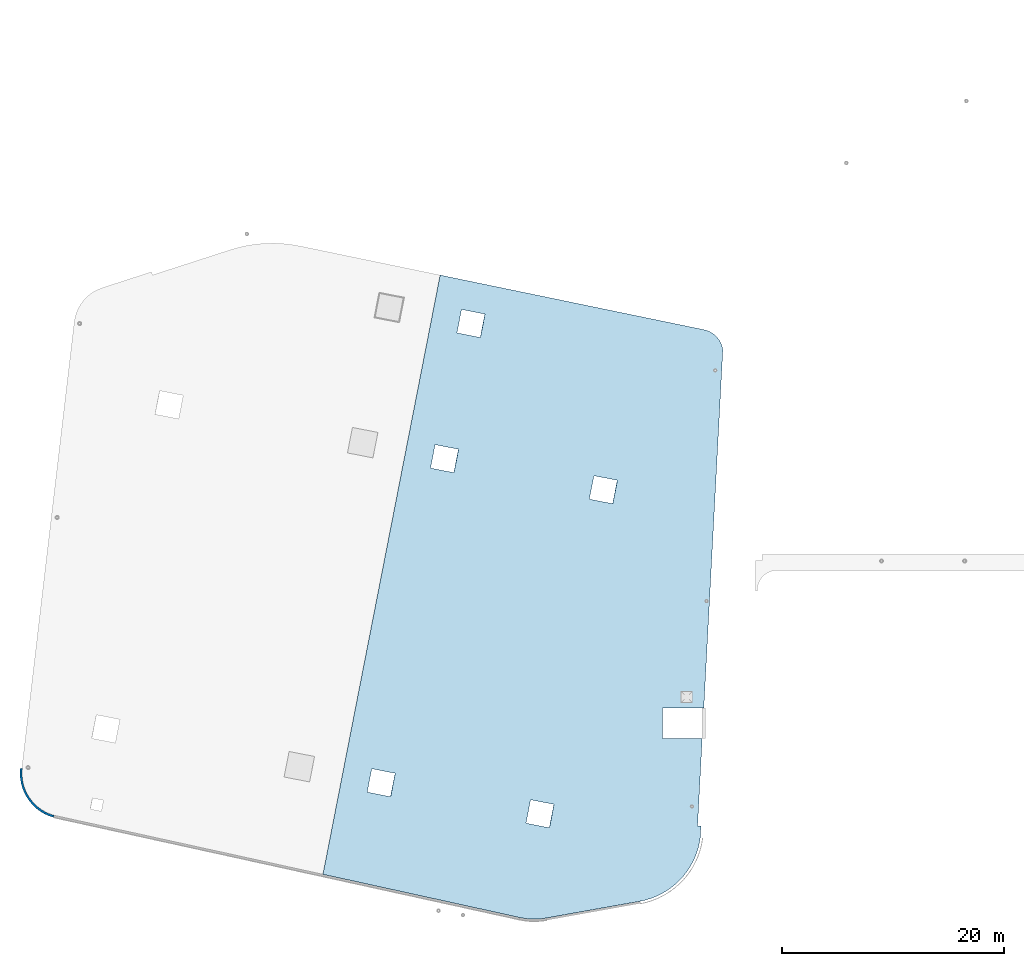
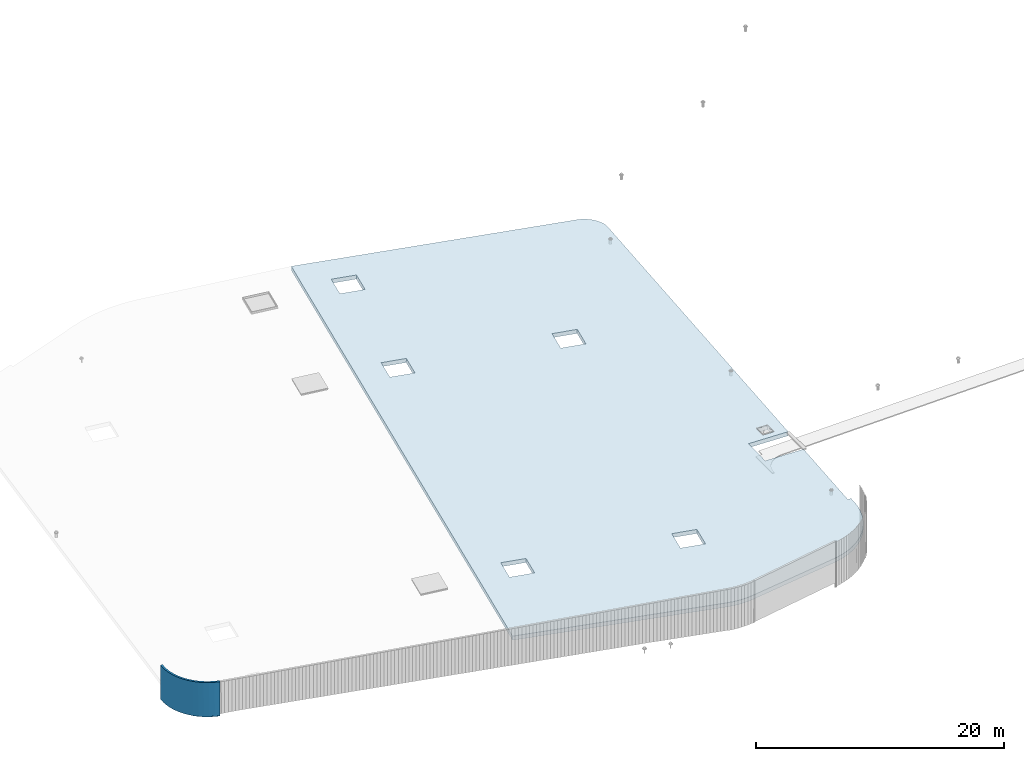
# One storey, part 9 of 18: 1 roof, 1 wall.
"""IFC2X3 building model written with IfcOpenShell, lengths in centimetres."""

from ifc_helpers import new_model, entity, si_unit, converted_unit, derived_unit, direction, frame, origin, place, context, subcontext, project, spatial, faceted_brep, material, layer, layer_set, type_object, element, save


model = new_model("IFC2X3")

# Units and contexts
model_context = context("Model", 3, precision=0.001, world=origin(), true_north=direction((6.12303176911189e-17, 1.0)))
body_context = subcontext(model_context, "Body", "Model", "MODEL_VIEW")
ifc_project = project(units=[si_unit("LENGTHUNIT", "METRE", prefix="CENTI"), si_unit("AREAUNIT", "SQUARE_METRE"), si_unit("VOLUMEUNIT", "CUBIC_METRE"), converted_unit("PLANEANGLEUNIT", "DEGREE", entity("IfcRatioMeasure", 0.0174532925199433), si_unit("PLANEANGLEUNIT", "RADIAN"), dimensions=[0, 0, 0, 0, 0, 0, 0]), si_unit("MASSUNIT", "GRAM", prefix="KILO"), derived_unit("MASSDENSITYUNIT", [(si_unit("MASSUNIT", "GRAM", prefix="KILO"), 1), (si_unit("LENGTHUNIT", "METRE"), -3)]), si_unit("TIMEUNIT", "SECOND"), si_unit("FREQUENCYUNIT", "HERTZ"), si_unit("THERMODYNAMICTEMPERATUREUNIT", "DEGREE_CELSIUS"), derived_unit("THERMALTRANSMITTANCEUNIT", [(si_unit("MASSUNIT", "GRAM", prefix="KILO"), 1), (si_unit("THERMODYNAMICTEMPERATUREUNIT", "KELVIN"), -1), (si_unit("TIMEUNIT", "SECOND"), -3)]), derived_unit("VOLUMETRICFLOWRATEUNIT", [(si_unit("LENGTHUNIT", "METRE"), 3), (si_unit("TIMEUNIT", "SECOND"), -1)]), si_unit("ELECTRICCURRENTUNIT", "AMPERE"), si_unit("ELECTRICVOLTAGEUNIT", "VOLT"), si_unit("POWERUNIT", "WATT"), si_unit("FORCEUNIT", "NEWTON", prefix="KILO"), si_unit("ILLUMINANCEUNIT", "LUX"), si_unit("LUMINOUSFLUXUNIT", "LUMEN"), si_unit("LUMINOUSINTENSITYUNIT", "CANDELA"), derived_unit("USERDEFINED", [(si_unit("MASSUNIT", "GRAM", prefix="KILO"), -1), (si_unit("LENGTHUNIT", "METRE"), -2), (si_unit("TIMEUNIT", "SECOND"), 3), (si_unit("LUMINOUSFLUXUNIT", "LUMEN"), 1)]), derived_unit("LINEARVELOCITYUNIT", [(si_unit("LENGTHUNIT", "METRE"), 1), (si_unit("TIMEUNIT", "SECOND"), -1)]), si_unit("PRESSUREUNIT", "PASCAL"), derived_unit("USERDEFINED", [(si_unit("LENGTHUNIT", "METRE"), -2), (si_unit("MASSUNIT", "GRAM", prefix="KILO"), 1), (si_unit("TIMEUNIT", "SECOND"), -2)])], contexts=[model_context])

# Site, building, storey
site_placement = place(None, origin())
site = spatial("IfcSite", under=ifc_project, at=site_placement, CompositionType="ELEMENT")
building_placement = place(site_placement, origin())
building = spatial("IfcBuilding", under=site, at=building_placement, CompositionType="ELEMENT")
storey_placement = place(building_placement, frame((0.0, 0.0, 1422.0)))
storey = spatial("IfcBuildingStorey", under=building, at=storey_placement, CompositionType="ELEMENT", Elevation=1422.0)

# Wall
ifc_material_1 = material(Name="Isolation")
ifc_layer_1 = layer(ifc_material_1, 10.0)
ifc_layer_2 = layer(ifc_material_1, 9.0)
ifc_material_2 = material(Name="Acier")
ifc_layer_3 = layer(ifc_material_2, 1.0)
ifc_layer_set = layer_set([ifc_layer_1, ifc_layer_2, ifc_layer_3])
wall_type = type_object("IfcWallType", PredefinedType="NOTDEFINED", material=ifc_layer_set)
wall_placement = place(storey_placement, frame((4062.69917392711, 1090.74013214278, -337.171375491842)))
element("IfcWall", 1, at=wall_placement, inside=storey, type_object=wall_type, context=body_context, shape_type="Brep", body=[
    faceted_brep([(-2.33072035438746, -8.43387471033597, 337.171375491841), (2.66368040501164, 9.63871395467039, 337.171375491841), (-18.5968051409579, 16.1678271243607, 337.171375491841), (-39.4533452253409, 23.8906698743825, 337.171375491841), (-59.8389745144359, 32.7824460141989, 337.171375491841), (-79.6882396558412, 42.8146061893157, 337.171375491841), (-98.9374094334242, 53.9549395463922, 337.171375491841), (-117.524679392928, 66.1676771545426, 337.171375491841), (-135.390370281209, 79.4136068507712, 337.171375491841), (-152.477119661962, 93.6501991407951, 337.171375491841), (-168.730066092708, 108.831743751021, 337.171375491841), (-184.097025271693, 124.909496393242, 337.171375491841), (-198.528657589123, 141.831835270817, 337.171375491841), (-211.978626544792, 159.54442682385, 337.171375491841), (-224.403747523429, 177.990400181178, 337.171375491841), (-235.76412645012, 197.11052975906, 337.171375491841), (-246.023287880582, 216.843425420284, 337.171375491841), (-255.148292115042, 237.125729583127, 337.171375491841), (-263.109840959691, 257.892320647317, 337.171375491841), (-269.882371796138, 279.076522083821, 337.171375491841), (-275.444139656826, 300.610316517149, 337.171375491841), (-279.777287042898, 322.424564112783, 337.171375491841), (-282.867901260324, 344.449224568555, 337.171375491841), (-284.706059090221, 366.613581997215, 337.171375491841), (-285.285858649921, 388.846471978133, 337.171375491841), (-284.605438342493, 411.076510049136, 337.171375491841), (-282.666982833885, 433.23232090485, 337.171375491841), (-301.291829289407, 435.395095629182, 337.171375491841), (-304.027845965021, 390.681654434054, 337.171375491841), (-301.884267243905, 345.93589842272, 337.171375491841), (-294.886527840281, 301.688760051991, 337.171375491841), (-283.117659695162, 258.465255412243, 337.171375491841), (-266.717306757722, 216.778254629184, 337.171375491841), (-245.880068034744, 177.122396384013, 337.171375491841), (-220.853188568764, 139.968218759488, 337.171375491841), (-191.933625742688, 105.756576052537, 337.171375491841), (-159.464525720749, 74.893407800965, 337.171375491841), (-123.831151834755, 47.7449220925424, 337.171375491841), (-85.4563132274757, 24.6332503091194, 337.171375491841), (-44.7953479948021, 5.83262486455579, 337.171375491841), (-282.482883397519, 256.567313356663, 0.15952722359159), (-294.568987883701, 300.221772277532, 0.15952722359159), (-301.780808834091, 344.94062002548, 0.15952722359159), (-304.030854899511, 390.181342809585, 0.15952722359159), (-301.291829289407, 435.395095629185, 0.15952722359159), (-282.666982833885, 433.23232090485, 0.15952722359159), (-284.605438342493, 411.076510049136, 0.15952722359159), (-285.285858649921, 388.846471978133, 0.15952722359159), (-284.706059090221, 366.613581997215, 0.15952722359159), (-282.867901260324, 344.449224568555, 0.15952722359159), (-279.777287042898, 322.424564112783, 0.15952722359159), (-275.444139656826, 300.610316517149, 0.15952722359159), (-269.882371796138, 279.076522083821, 0.15952722359159), (-263.109840959691, 257.892320647317, 0.15952722359159), (-255.148292115042, 237.125729583127, 0.15952722359159), (-246.023287880582, 216.843425420284, 0.15952722359159), (-235.76412645012, 197.11052975906, 0.15952722359159), (-224.403747523429, 177.990400181178, 0.15952722359159), (-211.978626544792, 159.54442682385, 0.15952722359159), (-198.528657589123, 141.831835270817, 0.15952722359159), (-184.097025271693, 124.909496393242, 0.15952722359159), (-168.730066092708, 108.831743751021, 0.15952722359159), (-152.477119661962, 93.6501991407951, 0.15952722359159), (-135.390370281209, 79.4136068507712, 0.15952722359159), (-117.524679392928, 66.1676771545426, 0.15952722359159), (-98.9374094334242, 53.9549395463922, 0.15952722359159), (-79.6882396558412, 42.8146061893157, 0.15952722359159), (-59.8389745144359, 32.7824460141989, 0.15952722359159), (-39.4533452253409, 23.8906698743825, 0.15952722359159), (-18.5968051409579, 16.1678271243607, 0.15952722359159), (2.66368040501164, 9.63871395467039, 0.15952722359159), (-2.66368040501424, -9.63871395466974, 0.15952722359159), (-23.7103234825644, -2.58312497189322, 0.15952722359159), (-44.7569665601129, 4.47246401088265, 0.15952722359159), (-64.9234442894792, 13.7490632100807, 0.15952722359159), (-85.0899220188463, 23.025662409279, 0.15952722359159), (-104.142641930281, 34.4158159181314, 0.15952722359159), (-123.195361841715, 45.8059694269839, 0.15952722359159), (-140.91363278646, 59.1777398507389, 0.15952722359159), (-158.631903731205, 72.549510274494, 0.15952722359159), (-170.567897284334, 83.7624266847847, 0.15952722359159), (-190.989080500356, 102.946503769046, 0.15952722359159), (-189.172921733311, 102.858487285105, 0.15952722359159), (-218.72941077487, 137.183400407514, 0.15952722359159), (-244.331676133505, 174.550628212513, 0.15952722359159), (-265.669119868183, 214.506844252001, 0.15952722359159), (-140.913599446718, 59.1777152729271, 2.22420308156823), (-123.195320261424, 45.8059414264352, 2.84912430087587), (-2.66368040502203, -9.63871395466757, 5.32638347245524), (-29.1064307092239, -0.774157690488049, 4.94767486458409), (-158.631878632013, 72.549489119419, 1.59928186226037), (-171.090299567969, 84.2531835625409, 1.04493635964215), (-149.772739039365, 65.863602196173, 1.91174247191419), (-104.142598564454, 34.41579002149, 3.37185078444104), (-64.9234056158152, 13.7490449343065, 4.30905413006593), (-44.7569343641454, 4.47245125206806, 4.72353099212565), (-85.0898768674842, 23.0256386165448, 3.89457726800621), (-2.33072035438746, -8.43387471033597, 5.26540626367174), (-84.040240700162, 23.8858423836643, 3.84907705526151), (-44.0509568302416, 5.53734730231245, 4.66863992297171), (-157.018869865278, 72.8265032417243, 1.58154341335571), (-121.840428771913, 46.4014671230987, 2.81610366581847)], [[[0, 1, 2, 3, 4, 5, 6, 7, 8, 9, 10, 11, 12, 13, 14, 15, 16, 17, 18, 19, 20, 21, 22, 23, 24, 25, 26, 27, 28, 29, 30, 31, 32, 33, 34, 35, 36, 37, 38, 39]], [[40, 41, 42, 43, 44, 45, 46, 47, 48, 49, 50, 51, 52, 53, 54, 55, 56, 57, 58, 59, 60, 61, 62, 63, 64, 65, 66, 67, 68, 69, 70, 71, 72, 73, 74, 75, 76, 77, 78, 79, 80, 81, 82, 83, 84, 85]], [[86, 77, 87]], [[88, 89, 72]], [[79, 90, 91, 81, 80]], [[90, 79, 92]], [[93, 76, 75]], [[89, 73, 72]], [[73, 94, 74]], [[73, 95, 94]], [[87, 76, 93]], [[88, 72, 71]], [[75, 74, 96]], [[89, 95, 73]], [[78, 86, 92]], [[77, 86, 78]], [[75, 96, 93]], [[77, 76, 87]], [[96, 74, 94]], [[79, 78, 92]], [[97, 88, 71, 70, 1, 0]], [[69, 68, 3, 2]], [[70, 69, 2, 1]], [[66, 65, 6, 5]], [[67, 66, 5, 4]], [[68, 67, 4, 3]], [[63, 62, 9, 8]], [[64, 63, 8, 7]], [[61, 60, 11, 10]], [[59, 58, 13, 12]], [[60, 59, 12, 11]], [[62, 61, 10, 9]], [[65, 64, 7, 6]], [[58, 57, 14, 13]], [[56, 55, 16, 15]], [[57, 56, 15, 14]], [[53, 52, 19, 18]], [[54, 53, 18, 17]], [[55, 54, 17, 16]], [[50, 49, 22, 21]], [[51, 50, 21, 20]], [[48, 47, 24, 23]], [[46, 45, 26, 25]], [[47, 46, 25, 24]], [[49, 48, 23, 22]], [[52, 51, 20, 19]], [[27, 26, 45, 44]], [[39, 38, 98]], [[0, 39, 99]], [[37, 36, 100]], [[35, 34, 83]], [[36, 35, 82]], [[38, 37, 101]], [[99, 97, 0]], [[98, 99, 39]], [[101, 37, 100]], [[82, 100, 36]], [[98, 38, 101]], [[82, 35, 83]], [[34, 84, 83]], [[32, 31, 40]], [[33, 32, 85]], [[30, 29, 42]], [[28, 27, 44]], [[29, 28, 43]], [[31, 30, 41]], [[33, 85, 84]], [[32, 40, 85]], [[31, 41, 40]], [[30, 42, 41]], [[43, 42, 29]], [[28, 44, 43]], [[33, 84, 34]], [[88, 97, 99, 98, 101, 100, 82, 81, 91, 90, 92, 86, 87, 93, 96, 94, 95, 89]]]),
])

# Roof
roof_placement = place(storey_placement, frame((6489.57797112554, 164.392622588099, -231.746341929982)))
element("IfcRoof", 2, at=roof_placement, inside=storey, material=ifc_material_1, ShapeType="NOTDEFINED", context=body_context, shape_type="Brep", body=[
    faceted_brep([(3605.55921956785, 5131.34931728668, 60.1974569138294), (3605.55921956785, 5131.34931728668, 20.1782415292171), (3602.75256792821, 5147.29479726882, 20.3584982715237), (3602.75256792821, 5147.29479726882, 60.377713656136), (3598.76484710722, 5162.98663297853, 20.5731784798952), (3598.76484710722, 5162.98663297853, 60.5923938645077), (3593.61825599826, 5178.3374709115, 20.8210870699026), (3593.61825599826, 5178.3374709115, 60.8403024545149), (3587.34144470813, 5193.26185583399, 61.1200593655657), (3587.34144470813, 5193.26185583399, 21.1008439809533), (3579.96935506722, 5207.67670649619, 21.4108918588288), (3579.96935506722, 5207.67670649619, 61.4301072434412), (3571.54302611498, 5221.50177812984, 21.7495047251827), (3571.54302611498, 5221.50177812984, 61.7687201097951), (3562.10936564321, 5234.66010915586, 22.1147975857395), (3562.10936564321, 5234.66010915586, 62.1340129703518), (3551.72088906925, 5247.078449615, 22.5047369237026), (3551.72088906925, 5247.078449615, 62.5239523083149), (3540.43542709247, 5258.68766893662, 22.9171520199623), (3540.43542709247, 5258.68766893662, 62.9363674045747), (3528.31580376161, 5269.42314077557, 23.3497470370799), (3528.31580376161, 5269.42314077557, 63.3689624216923), (3515.42948674513, 5279.22510277498, 23.8001137997851), (3515.42948674513, 5279.22510277498, 63.8193291843974), (3501.84821175136, 5288.03898925204, 64.2849605854476), (3501.84821175136, 5288.03898925204, 24.265745200835), (3487.64758318923, 5295.81573495493, 24.744049157611), (3487.64758318923, 5295.81573495493, 64.7632645422234), (3472.90665329277, 5302.51204819987, 25.2323630417533), (3472.90665329277, 5302.51204819987, 65.2515784263655), (3457.7074820521, 5308.09065186779, 25.7279685015164), (3457.7074820521, 5308.09065186779, 65.7471838861288), (3442.13468040093, 5312.52049091908, 66.2473219789343), (3442.13468040093, 5312.52049091908, 26.228106594322), (2013.31416061721, 9.81361279296605, 78.1688133992023), (2013.31147847183, 9.81313381793765, 38.1496767657806), (2851.05250658396, 159.416147481629, 13.5525375923507), (2851.05250658396, 159.416147481629, 53.571752976963), (2962.45255731718, 188.576681389899, 50.356039288653), (2907.38064147428, 171.598800580734, 11.9113066656962), (2962.45346921057, 188.577006077348, 10.3367980925785), (2907.38017326315, 171.598678019688, 51.9305355658571), (3015.86352253749, 210.225147345656, 8.84066118742633), (3015.86220161086, 210.224544569815, 48.8599131733247), (3116.12987248151, 266.857198492333, 6.12711849732853), (3162.24432859226, 301.422104891247, 4.92978939697696), (3162.24208200281, 301.420264896865, 44.9490621841344), (3116.1278754816, 266.855831721227, 46.146386506492), (3067.21563656643, 236.38305631243, 7.43396541631643), (3067.21395091295, 236.382104231376, 47.4532264203673), (3205.21781793526, 339.822040183419, 3.85083679244105), (3205.21539108505, 339.819676225102, 43.870111946469), (3244.72986150047, 381.769964801255, 42.9175184871895), (3312.24063677556, 475.0577092425, 41.4186062344574), (3280.49569619764, 426.964287070282, 2.07905755677673), (3312.24312678195, 475.061859441977, 1.39933978625883), (3280.49314249666, 426.960758290862, 42.0983296399525), (3244.73239261362, 381.772894820061, 2.89824352888177), (3339.73979469527, 525.709752492145, 0.864119244268215), (3339.73745813621, 525.704968782322, 40.883377254945), (3381.20003957153, 633.14149008852, 0.241911198023814), (3394.85686467736, 689.130479584536, 0.15952722359159), (3394.85554356376, 689.123833814277, 40.178743262268), (3381.19828704564, 633.135447266424, 40.2611439491221), (3362.78226037825, 578.533237723665, 0.477355866297808), (3362.78016929782, 578.52781938844, 40.4966026328838), (3403.65169296248, 746.085960551615, 0.230813477200475), (3403.65089462264, 746.078744784133, 40.2500102199412), (0.0, 403.83228423563, 141.765557314594), (0.0, 403.83228423563, 101.746341929982), (1775.10719215225, 13.9291663111946, 45.42122758734), (1775.10719215225, 13.9291663111946, 85.4404429719524), (1459.52962508291, 5455.14923422199, 87.394915886874), (1056.51074680815, 5806.45314967378, 101.746341929982), (1418.27983128063, 5244.14341792516, 87.3945052764485), (2442.10621611886, 3997.77245306138, 48.8305821046172), (2653.0107195799, 3956.54247799712, 42.1687823433927), (3328.28664665757, 2054.23932234637, 10.306582441776), (3434.1060276512, 1902.10126012863, 6.18201408689116), (3328.28664391607, 1954.24109213772, 9.71164115332645), (3228.33289033837, 1954.22300323694, 12.7524993413735), (3062.8291601359, 1902.10126012863, 17.4776405052776), (3228.33289307987, 2054.22123344559, 13.3474406298234), (2611.7609257776, 3745.53666170025, 42.1683717329673), (2400.85642231658, 3786.76663676452, 48.8301714941913), (1870.98356721406, 1076.29843756972, 48.8248970116186), (2081.88807067509, 1035.06846250543, 42.1630972503943), (3062.8291601359, 1628.10126012863, 15.8474722958155), (3377.78531043767, 841.324469638681, 1.58438858322042), (3419.55831445215, 1628.10126012863, 4.99444154636486), (3407.82756502357, 841.324469638682, 0.670391202129972), (2040.6382768728, 824.062646208588, 42.1626866399688), (1960.52829032351, 2.69326021489728, 39.713178299961), (1907.32737164393, 0.15952722359159, 41.3166740849531), (1880.69451082086, 0.619727676866446, 42.1296829690106), (1827.61288870202, 4.98996158992732, 43.7706245902516), (1829.73377341177, 865.292621272833, 48.8244864011929), (608.908803909016, 1103.95316300828, 87.3864486014597), (969.126949352791, 4066.65715356422, 94.0539334556824), (398.004300447988, 1145.18313807253, 94.0482483626838), (439.25409425028, 1356.18895436941, 94.0486589731094), (650.158597711306, 1314.95897930513, 87.3868592118852), (1180.03145281382, 4025.42717849995, 87.3921336944582), (1221.28124661611, 4236.43299479682, 87.3925443048838), (1010.37674315508, 4277.66296986108, 94.0543440661081), (1207.37532781961, 5285.37339298946, 94.0563050376726), (1248.62512162189, 5496.37920928629, 94.0567156480982), (1056.51074680815, 5806.45314967377, 141.765557314594), (1460.74598987873, 5454.91136772891, 127.375709728604), (1249.84148641771, 5496.14134279319, 134.037509489829), (1208.59169261542, 5285.13552649634, 134.037098879403), (1011.59310795089, 4277.42510336795, 134.035137907838), (970.343314148606, 4066.41928707113, 134.034727297413), (440.470459046102, 1355.95108787633, 134.02945281484), (399.220665243806, 1144.94527157946, 134.029042204414), (610.125168704833, 1103.71529651517, 127.36724244319), (1830.95013820759, 865.054754779765, 88.8052802429234), (2041.85464166862, 823.824779715476, 82.1434804816991), (1827.61348941003, 4.98988587008813, 83.7898212485899), (1880.6957208278, 0.619680584793343, 82.148861260526), (1907.32888528335, 0.159533801940963, 81.3358434581494), (1960.53040070204, 2.69345244326622, 79.7323306226573), (2083.1044354709, 1034.83059601234, 82.1438910921248), (3377.78531043767, 841.324469638681, 41.6036039678326), (3407.82756502359, 841.324469638681, 40.6896065867417), (3062.8291601359, 1628.10126012863, 55.8666876804278), (3419.55831445215, 1628.10126012863, 45.0136569309772), (3062.8291601359, 1902.10126012863, 57.49685588989), (1872.19993200989, 1076.06057107663, 88.8056908533489), (2402.07278711239, 3786.52877027143, 88.8109653359218), (2612.97729057341, 3745.29879520713, 82.1491655746978), (3229.54925787569, 2053.98336695249, 53.3282344715537), (3229.54925513419, 1953.98513674383, 52.733293183104), (3434.1060276512, 1902.10126012863, 46.2012294715035), (3329.50300871189, 1954.0032256446, 49.6924349950567), (3329.50301145339, 2054.00145585327, 50.2873762835065), (2654.22708437571, 3956.304611504, 82.1495761851235), (2443.32258091468, 3997.53458656825, 88.8113759463475), (1181.24781760963, 4025.18931200683, 127.372927536189), (651.374962507121, 1314.72111281203, 127.367653053616), (1419.49619607644, 5243.90555143203, 127.375299118179), (1222.49761141192, 4236.1951283037, 127.373338146614), (3419.55831445215, 1628.10126012863, 31.7463419299818)], [[[0, 1, 2, 3]], [[3, 2, 4, 5]], [[6, 7, 5, 4]], [[8, 9, 10, 11]], [[10, 12, 13, 11]], [[9, 8, 7, 6]], [[13, 12, 14, 15]], [[16, 17, 15, 14]], [[17, 16, 18, 19]], [[19, 18, 20, 21]], [[22, 23, 21, 20]], [[24, 25, 26, 27]], [[26, 28, 29, 27]], [[25, 24, 23, 22]], [[29, 28, 30, 31]], [[32, 31, 30, 33]], [[34, 35, 36, 37]], [[38, 39, 40]], [[39, 41, 36]], [[42, 43, 40]], [[44, 45, 46]], [[47, 48, 44]], [[48, 49, 42]], [[45, 50, 51]], [[43, 38, 40]], [[41, 37, 36]], [[38, 41, 39]], [[51, 46, 45]], [[47, 49, 48]], [[46, 47, 44]], [[43, 42, 49]], [[50, 52, 51]], [[53, 54, 55]], [[54, 56, 57]], [[58, 59, 55]], [[60, 61, 62]], [[63, 64, 60]], [[64, 65, 58]], [[61, 66, 62]], [[59, 53, 55]], [[56, 52, 57]], [[53, 56, 54]], [[67, 62, 66]], [[63, 65, 64]], [[62, 63, 60]], [[59, 58, 65]], [[57, 52, 50]], [[68, 69, 70, 71]], [[33, 72, 73]], [[33, 74, 72]], [[75, 74, 33]], [[75, 33, 76]], [[76, 33, 1]], [[30, 1, 33]], [[30, 28, 1]], [[28, 26, 1]], [[25, 1, 26]], [[1, 25, 22]], [[22, 20, 1]], [[18, 1, 20]], [[16, 1, 18]], [[16, 14, 1]], [[14, 12, 1]], [[10, 1, 12]], [[9, 1, 10]], [[6, 1, 9]], [[1, 6, 4]], [[4, 2, 1]], [[76, 1, 77]], [[1, 78, 77]], [[77, 78, 79]], [[78, 80, 79]], [[80, 78, 81]], [[81, 82, 80]], [[81, 83, 82]], [[84, 83, 81]], [[84, 81, 85]], [[85, 81, 86]], [[86, 81, 87]], [[86, 87, 88]], [[88, 87, 89]], [[36, 86, 88]], [[88, 39, 36]], [[39, 88, 40]], [[88, 42, 40]], [[42, 88, 48]], [[88, 44, 48]], [[88, 45, 44]], [[50, 45, 88]], [[88, 57, 50]], [[57, 88, 54]], [[54, 88, 55]], [[88, 58, 55]], [[64, 58, 88]], [[88, 60, 64]], [[61, 60, 88]], [[66, 61, 88]], [[66, 88, 90]], [[91, 86, 36]], [[36, 35, 91]], [[35, 92, 91]], [[92, 93, 91]], [[94, 91, 93]], [[91, 94, 95]], [[70, 91, 95]], [[96, 91, 70]], [[70, 97, 96]], [[97, 70, 69]], [[98, 69, 73]], [[97, 69, 99]], [[100, 99, 69]], [[69, 98, 100]], [[100, 98, 101]], [[97, 101, 96]], [[101, 85, 96]], [[85, 101, 84]], [[102, 75, 84]], [[102, 84, 101]], [[101, 98, 102]], [[102, 103, 75]], [[74, 75, 103]], [[103, 104, 74]], [[73, 104, 98]], [[104, 73, 105]], [[74, 104, 105]], [[106, 105, 73]], [[83, 76, 77]], [[83, 77, 82]], [[106, 73, 72]], [[107, 108, 32]], [[108, 107, 109]], [[107, 110, 109]], [[110, 107, 111]], [[112, 111, 107]], [[107, 68, 112]], [[113, 112, 68]], [[68, 114, 113]], [[114, 68, 115]], [[68, 71, 115]], [[116, 115, 71]], [[71, 117, 116]], [[118, 117, 71]], [[118, 119, 117]], [[120, 117, 119]], [[117, 120, 121]], [[117, 121, 34]], [[117, 34, 37]], [[37, 122, 117]], [[123, 122, 37]], [[37, 41, 123]], [[38, 123, 41]], [[38, 43, 123]], [[49, 123, 43]], [[49, 47, 123]], [[47, 46, 123]], [[123, 46, 51]], [[51, 52, 123]], [[56, 123, 52]], [[53, 123, 56]], [[53, 59, 123]], [[123, 59, 65]], [[63, 123, 65]], [[123, 63, 62]], [[62, 67, 123]], [[124, 123, 67]], [[123, 125, 122]], [[126, 125, 123]], [[125, 127, 122]], [[122, 127, 128]], [[128, 127, 129]], [[127, 130, 129]], [[131, 130, 127]], [[132, 131, 127]], [[132, 127, 133]], [[132, 133, 134]], [[134, 133, 135]], [[135, 133, 0]], [[32, 0, 31]], [[0, 29, 31]], [[0, 27, 29]], [[0, 32, 136]], [[135, 0, 136]], [[27, 0, 24]], [[23, 24, 0]], [[0, 21, 23]], [[21, 0, 19]], [[19, 0, 17]], [[0, 15, 17]], [[0, 13, 15]], [[13, 0, 11]], [[11, 0, 8]], [[8, 0, 7]], [[5, 7, 0]], [[0, 3, 5]], [[136, 32, 137]], [[135, 136, 130]], [[131, 135, 130]], [[129, 137, 138]], [[139, 129, 138]], [[129, 139, 128]], [[116, 128, 139]], [[138, 112, 139]], [[116, 139, 115]], [[139, 112, 113]], [[110, 111, 140]], [[140, 111, 141]], [[141, 137, 140]], [[137, 141, 138]], [[108, 140, 32]], [[32, 140, 137]], [[107, 73, 69, 68]], [[100, 113, 114, 99]], [[104, 111, 112, 98]], [[106, 109, 110, 105]], [[99, 114, 115, 97]], [[96, 116, 117, 91]], [[97, 115, 139, 101]], [[102, 138, 141, 103]], [[74, 140, 108, 72]], [[101, 139, 113, 100]], [[85, 86, 122, 128]], [[85, 128, 116, 96]], [[75, 137, 129, 84]], [[86, 91, 117, 122]], [[76, 83, 130, 136]], [[83, 84, 129, 130]], [[102, 98, 112, 138]], [[75, 76, 136, 137]], [[103, 141, 111, 104]], [[105, 110, 140, 74]], [[72, 108, 109, 106]], [[82, 131, 132, 80]], [[79, 80, 132, 134]], [[79, 134, 135, 77]], [[77, 135, 131, 82]], [[142, 89, 87, 125, 126]], [[127, 81, 78, 133]], [[125, 87, 81, 127]], [[123, 88, 89, 142, 126]], [[133, 78, 1, 0]], [[67, 66, 90]], [[90, 124, 67]], [[124, 90, 88, 123]], [[32, 33, 73, 107]], [[118, 70, 95]], [[119, 95, 94]], [[118, 71, 70]], [[119, 118, 95]], [[94, 120, 119]], [[121, 93, 92]], [[34, 92, 35]], [[121, 120, 93]], [[34, 121, 92]], [[93, 120, 94]]]),
])

save(model, "model.ifc")
